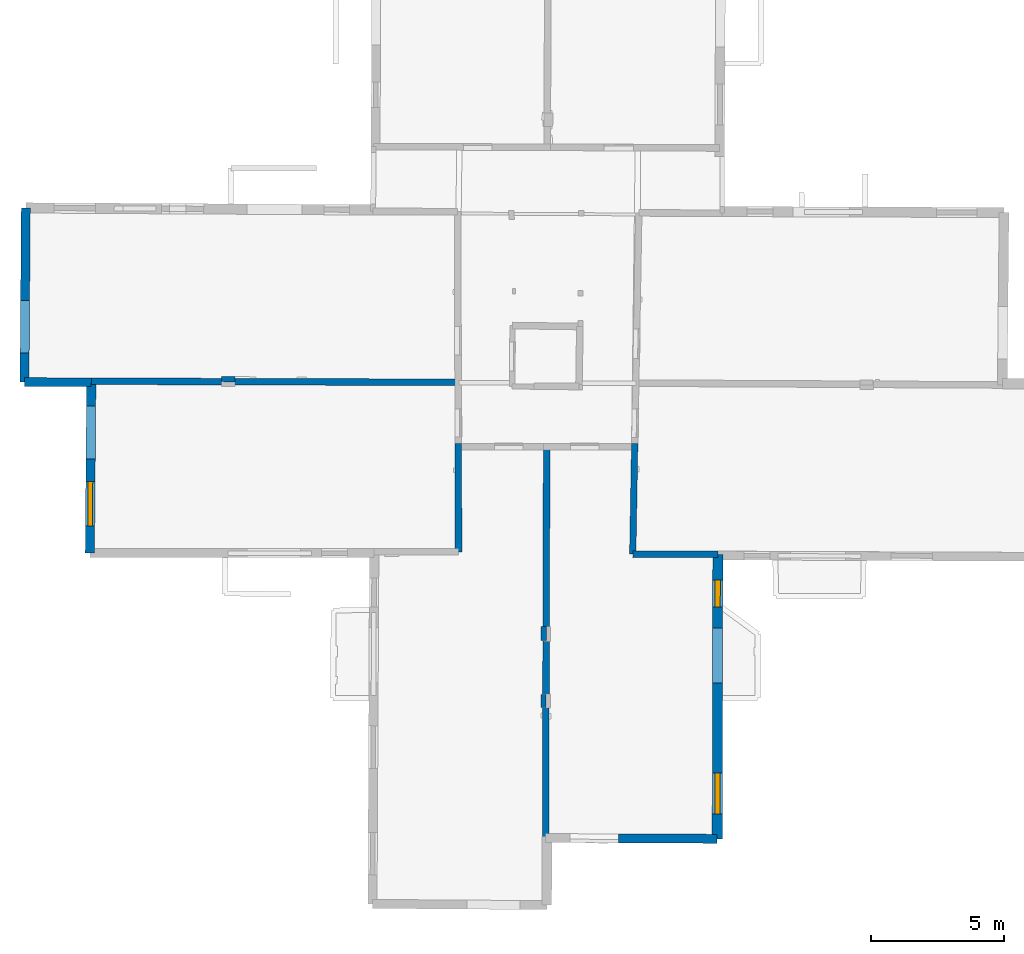
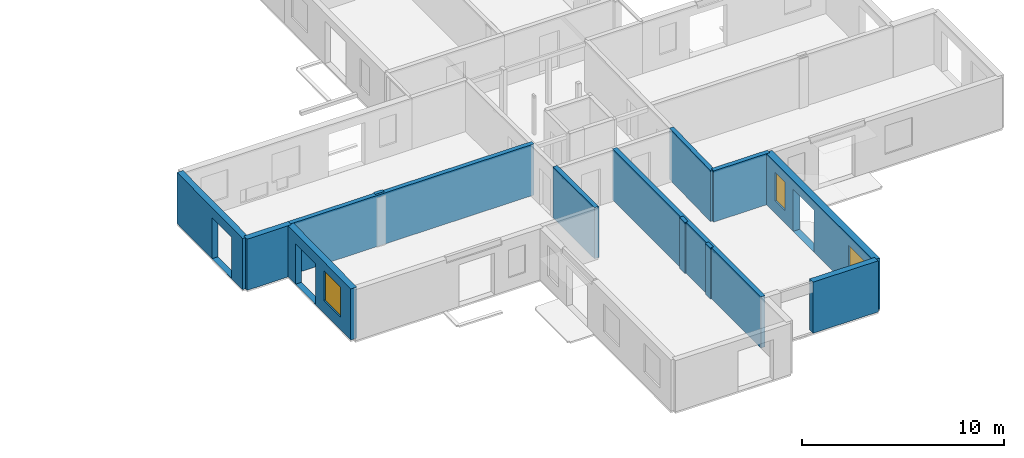
# One storey, part 4 of 17: 13 walls, 3 windows, 6 openings.
"""IFC2X3 building model written with IfcOpenShell, lengths in metres."""

from ifc_helpers import new_model, entity, si_unit, converted_unit, derived_unit, direction, frame, frame_2d, origin, origin_2d_with_axis, place, context, subcontext, project, spatial, polyline, rectangle, outline, extrude, clip, halfspace, source, transform, mapped, material, layer, layer_set, layer_usage, type_object, type_shapes, element, fill, save


model = new_model("IFC2X3")

# Units and contexts
model_context = context("Model", 3, precision=1e-05, world=origin(), true_north=direction((0.0, 1.0)))
body_context = subcontext(model_context, "Body", "Model", "MODEL_VIEW")
ifc_project = project(units=[si_unit("LENGTHUNIT", "METRE"), si_unit("AREAUNIT", "SQUARE_METRE"), si_unit("VOLUMEUNIT", "CUBIC_METRE"), converted_unit("PLANEANGLEUNIT", "DEGREE", entity("IfcRatioMeasure", 0.0174532925199433), si_unit("PLANEANGLEUNIT", "RADIAN"), dimensions=[0, 0, 0, 0, 0, 0, 0]), si_unit("MASSUNIT", "GRAM", prefix="KILO"), derived_unit("MASSDENSITYUNIT", [(si_unit("MASSUNIT", "GRAM", prefix="KILO"), 1), (si_unit("LENGTHUNIT", "METRE"), -3)]), derived_unit("MOMENTOFINERTIAUNIT", [(si_unit("LENGTHUNIT", "METRE"), 4)]), si_unit("TIMEUNIT", "SECOND"), si_unit("FREQUENCYUNIT", "HERTZ"), si_unit("THERMODYNAMICTEMPERATUREUNIT", "DEGREE_CELSIUS"), derived_unit("THERMALTRANSMITTANCEUNIT", [(si_unit("MASSUNIT", "GRAM", prefix="KILO"), 1), (si_unit("THERMODYNAMICTEMPERATUREUNIT", "KELVIN"), -1), (si_unit("TIMEUNIT", "SECOND"), -3)]), derived_unit("VOLUMETRICFLOWRATEUNIT", [(si_unit("LENGTHUNIT", "METRE"), 3), (si_unit("TIMEUNIT", "SECOND"), -1)]), si_unit("ELECTRICCURRENTUNIT", "AMPERE"), si_unit("ELECTRICVOLTAGEUNIT", "VOLT"), si_unit("POWERUNIT", "WATT"), si_unit("FORCEUNIT", "NEWTON", prefix="KILO"), si_unit("ILLUMINANCEUNIT", "LUX"), si_unit("LUMINOUSFLUXUNIT", "LUMEN"), si_unit("LUMINOUSINTENSITYUNIT", "CANDELA"), derived_unit("USERDEFINED", [(si_unit("MASSUNIT", "GRAM", prefix="KILO"), -1), (si_unit("LENGTHUNIT", "METRE"), -2), (si_unit("TIMEUNIT", "SECOND"), 3), (si_unit("LUMINOUSFLUXUNIT", "LUMEN"), 1)]), derived_unit("LINEARVELOCITYUNIT", [(si_unit("LENGTHUNIT", "METRE"), 1), (si_unit("TIMEUNIT", "SECOND"), -1)]), si_unit("PRESSUREUNIT", "PASCAL"), derived_unit("USERDEFINED", [(si_unit("LENGTHUNIT", "METRE"), -2), (si_unit("MASSUNIT", "GRAM", prefix="KILO"), 1), (si_unit("TIMEUNIT", "SECOND"), -2)]), derived_unit("LINEARFORCEUNIT", [(si_unit("MASSUNIT", "GRAM", prefix="KILO"), 1), (si_unit("LENGTHUNIT", "METRE"), 1), (si_unit("TIMEUNIT", "SECOND"), -2), (si_unit("LENGTHUNIT", "METRE"), -1)]), derived_unit("PLANARFORCEUNIT", [(si_unit("MASSUNIT", "GRAM", prefix="KILO"), 1), (si_unit("LENGTHUNIT", "METRE"), 1), (si_unit("TIMEUNIT", "SECOND"), -2), (si_unit("LENGTHUNIT", "METRE"), -2)])], contexts=[model_context])

# Site, building, storey
placement = place(None, origin())
site = spatial("IfcSite", under=ifc_project, at=placement, CompositionType="ELEMENT")
building = spatial("IfcBuilding", under=site, at=placement, CompositionType="ELEMENT")
storey_placement = place(placement, frame((0.0, 0.0, 12.0782108306885)))
storey = spatial("IfcBuildingStorey", under=building, at=storey_placement, Name="Level 5", CompositionType="ELEMENT", Elevation=12.0782108306885)

# Walls
ifc_material_1 = material(Name="Default wall")
ifc_layer_1 = layer(ifc_material_1, 0.25)
ifc_layer_set_1 = layer_set([ifc_layer_1], Name="wall_thickness_0.2500")
ifc_layer_usage_1 = layer_usage(ifc_layer_set_1, "AXIS2", "POSITIVE", -0.125)
wall_type_1 = type_object("IfcWallType", Name="wall_thickness_0.2500", PredefinedType="STANDARD", material=ifc_layer_set_1)
wall_1_placement = place(storey_placement, frame((9.43781448471923, 12.9598951687041, 0.0), z_axis=(0.0, 0.0, 1.0), x_axis=(0.999992090517614, -0.00397729835595546, 0.0)))
element("IfcWallStandardCase", 1, at=wall_1_placement, inside=storey, type_object=wall_type_1, material=ifc_layer_usage_1, Name="Wall:256", ObjectType="Wall", context=body_context, shape_type="Clipping", body=[
    clip(clip(extrude(outline(polyline([(3.20824871848224, -0.125), (3.20824871848224, 0.125), (0.0, 0.125), (0.0, -0.125), (3.20824871848224, -0.125)])), origin(), (0.0, 0.0, 1.0), 3.09134044647217), halfspace(frame((-21.4971284147456, 6.54858542448674, 8.98689858314154), z_axis=(-0.00274595681846049, -0.389131818215703, 0.921177989192801), x_axis=(0.999982875526521, -0.0058292237624909, 0.000518463148508191)), False)), halfspace(frame((3.12303559283847, 64.2896526154921, 6.35864093399329), z_axis=(0.390499965286764, -0.000350666726695465, 0.920602875372374), x_axis=(-0.681032629723905, -0.672971905623566, 0.288623234499112)), False)),
])
wall_2_placement = place(storey_placement, frame((2.85603882370737, 17.1352351598034, 0.0), z_axis=(0.0, 0.0, 1.0), x_axis=(0.00271867720690838, -0.999996304390294, 0.0)))
element("IfcWallStandardCase", 2, at=wall_2_placement, inside=storey, type_object=wall_type_1, material=ifc_layer_usage_1, Name="Wall:278", ObjectType="Wall", context=body_context, shape_type="Clipping", body=[
    clip(clip(extrude(outline(polyline([(4.09139428584585, -0.125), (4.09139428584585, 0.125), (0.0, 0.125), (0.0, -0.125), (4.09139428584585, -0.125)])), origin(), (0.0, 0.0, 1.0), 3.09134044647217), halfspace(frame((-2.49916380210772, -14.8823976244006, 8.98689858314154), z_axis=(0.389104707877538, -0.00535149831765918, 0.921177989192801), x_axis=(0.0125249177791981, 0.999921425728336, 0.000518463148508191)), False)), halfspace(frame((-58.7195490774422, -3.95921476846437, 5.79573318480268), z_axis=(-0.00247443177286369, -0.389892921938171, 0.920856876289642), x_axis=(0.00805044237294521, 0.920820823416222, 0.389902810378011)), False)),
])
wall_3_placement = place(storey_placement, frame((6.19052646799944, 17.0089868537105, 0.0), z_axis=(0.0, 0.0, 1.0), x_axis=(-0.00281216975560108, -0.999996045842815, 0.0)))
element("IfcWallStandardCase", 3, at=wall_3_placement, inside=storey, type_object=wall_type_1, material=ifc_layer_usage_1, Name="Wall:351", ObjectType="Wall", context=body_context, shape_type="Clipping", body=[
    clip(extrude(outline(polyline([(14.7613904039226, -0.125), (14.7613904039226, 0.125), (0.0, 0.125), (0.0, -0.125), (14.7613904039226, -0.125)])), origin(), (0.0, 0.0, 1.0), 3.09134044647217), halfspace(frame((-60.2460264700431, 6.45660151449887, 6.35864093399329), z_axis=(0.000805651711142417, 0.390499291652927, 0.920602875372374), x_axis=(0.672177953798088, -0.681816270658809, 0.288623234499112)), False)),
])
wall_4_placement = place(storey_placement, frame((-10.9863826163068, 19.4781709457927, 0.0), z_axis=(0.0, 0.0, 1.0), x_axis=(0.99999559192, -0.00296919864096198, 0.0)))
element("IfcWallStandardCase", 4, at=wall_4_placement, inside=storey, type_object=wall_type_1, material=ifc_layer_usage_1, Name="Wall:367", ObjectType="Wall", context=body_context, shape_type="Clipping", body=[
    clip(extrude(outline(polyline([(13.8907873211793, -0.125), (13.8907873211793, 0.125), (0.0, 0.125), (0.0, -0.125), (13.8907873211793, -0.125)])), origin(), (0.0, 0.0, 1.0), 3.09134044647217), halfspace(frame((-1.04705470003284, 0.112649928156324, 8.98689858314154), z_axis=(-0.00313824141450819, -0.389128852268156, 0.921177989192801), x_axis=(0.999976490923063, -0.00683730920472676, 0.000518463148508191)), False)),
])
ifc_layer_2 = layer(ifc_material_1, 0.330000013113022)
ifc_layer_set_2 = layer_set([ifc_layer_2], Name="wall_thickness_0.3300")
ifc_layer_usage_2 = layer_usage(ifc_layer_set_2, "AXIS2", "POSITIVE", -0.165000006556511)
wall_type_2 = type_object("IfcWallType", Name="wall_thickness_0.3300", PredefinedType="STANDARD", material=ifc_layer_set_2)
wall_5_placement = place(storey_placement, frame((-13.5041588449196, 19.4468160164166, 0.0), z_axis=(0.0, 0.0, 1.0), x_axis=(0.999997135838471, -0.00239338982485453, 0.0)))
element("IfcWallStandardCase", 5, at=wall_5_placement, inside=storey, type_object=wall_type_2, material=ifc_layer_usage_2, Name="Wall:247", ObjectType="Wall", context=body_context, shape_type="SweptSolid", body=[
    extrude(outline(polyline([(2.51748138497284, -0.165000006556511), (2.51748138497284, 0.165000006556511), (0.0, 0.165000006556511), (0.0, -0.165000006556511), (2.51748138497284, -0.165000006556511)])), origin(), (0.0, 0.0, 1.0), 3.09134044647217),
])

# Wall, openings, window
ifc_layer_3 = layer(ifc_material_1, 0.349999994039536)
ifc_layer_set_3 = layer_set([ifc_layer_3], Name="wall_thickness_0.3500")
ifc_layer_usage_3 = layer_usage(ifc_layer_set_3, "AXIS2", "POSITIVE", -0.174999997019768)
wall_type_3 = type_object("IfcWallType", Name="wall_thickness_0.3500", PredefinedType="STANDARD", material=ifc_layer_set_3)
wall_6_placement = place(storey_placement, frame((-10.9863817701977, 19.4781705652483, 0.0), z_axis=(0.0, 0.0, 1.0), x_axis=(-0.00811924451984643, -0.99996703839098, 0.0)))
wall_6 = element("IfcWallStandardCase", 6, at=wall_6_placement, inside=storey, type_object=wall_type_3, material=ifc_layer_usage_3, Name="Wall:234", ObjectType="Wall", context=body_context, shape_type="Clipping", body=[
    clip(extrude(outline(polyline([(6.47783650575404, -0.174999997019768), (6.47783650575404, 0.174999997019768), (0.0, 0.174999997019768), (0.0, -0.174999997019768), (6.47783650575404, -0.174999997019768)])), origin(), (0.0, 0.0, 1.0), 3.09134044647217), halfspace(frame((-0.107256363123766, -1.04762182256688, 8.98689858314154), z_axis=(0.389139853964676, -0.00113414419666369, 0.921177989192801), x_axis=(0.00168723164517169, 0.999998442221456, 0.000518463148508191)), False)),
])
opening_1_placement = place(wall_6_placement, frame((0.936069885868087, -0.174999997019768, 0.00578975677490234)))
element("IfcOpeningElement", 7, at=opening_1_placement, cuts=wall_6, Name="Opening : 1995 x 2445 : 208", ObjectType="Opening", context=body_context, shape_type="SweptSolid", body=[
    extrude(rectangle(XDim=1.995, YDim=2.445, at=frame_2d((1.2225, 0.9975), x_axis=(0.0, 1.0))), frame((0.0, 0.0, 0.0), z_axis=(0.0, 1.0, 0.0), x_axis=(0.0, 0.0, 1.0)), (0.0, 0.0, 1.0), 0.349999994039536),
])
opening_2_placement = place(wall_6_placement, frame((3.77431154989189, -0.174999997019768, 0.745789527893066)))
opening_2 = element("IfcOpeningElement", 8, at=opening_2_placement, cuts=wall_6, Name="Opening : 1685 x 1830 : 209", ObjectType="Opening", context=body_context, shape_type="SweptSolid", body=[
    extrude(rectangle(XDim=1.685, YDim=1.83, at=frame_2d((0.915, 0.8425), x_axis=(0.0, 1.0))), frame((0.0, 0.0, 0.0), z_axis=(0.0, 1.0, 0.0), x_axis=(0.0, 0.0, 1.0)), (0.0, 0.0, 1.0), 0.349999994039536),
])
ifc_material_2 = material(Name="Window Default")
window_style_1 = type_object("IfcWindowStyle", Name="Window : 1685 x 1830mm", ConstructionType="NOTDEFINED", OperationType="NOTDEFINED", ParameterTakesPrecedence=False, Sizeable=False, material=ifc_material_2)
shared_shape_1 = source(origin(), body_context, "Body", "SweptSolid", [
    extrude(rectangle(XDim=0.174999997019768, YDim=1.685, at=origin_2d_with_axis()), frame((0.8425, 0.174999997019768, 0.0), z_axis=(0.0, 0.0, 1.0), x_axis=(0.0, 1.0, 0.0)), (0.0, 0.0, 1.0), 1.83),
])
type_shapes(window_style_1, [shared_shape_1])
window_1_placement = place(opening_2_placement, origin())
window_1 = element("IfcWindow", 9, at=window_1_placement, inside=storey, type_object=window_style_1, Name="Window : 1685 x 1830mm : 111", ObjectType="Window : 1685 x 1830mm", OverallHeight=1.83, OverallWidth=1.685, context=body_context, shape_type="MappedRepresentation", body=[
    mapped(shared_shape_1, transform((0.0, 0.0, 0.0), scale=1.0)),
])
fill(opening_2, window_1)

# Walls
ifc_layer_4 = layer(ifc_material_1, 0.2)
ifc_layer_set_4 = layer_set([ifc_layer_4], Name="wall_thickness_0.2000")
ifc_layer_usage_4 = layer_usage(ifc_layer_set_4, "AXIS2", "POSITIVE", -0.1)
wall_type_4 = type_object("IfcWallType", Name="wall_thickness_0.2000", PredefinedType="STANDARD", material=ifc_layer_set_4)
wall_7_placement = place(storey_placement, frame((6.07211114635304, 7.6596113359581, 0.0), z_axis=(0.0, 0.0, 1.0), x_axis=(0.00125519004012182, -0.999999212248671, 0.0)))
element("IfcWallStandardCase", 10, at=wall_7_placement, inside=storey, type_object=wall_type_4, material=ifc_layer_usage_4, Name="Wall:246", ObjectType="Wall", context=body_context, shape_type="Clipping", body=[
    clip(extrude(outline(polyline([(0.494999798658673, -0.1), (0.494999798658673, 0.1), (0.0, 0.1), (0.0, -0.1), (0.494999798658673, -0.1)])), origin(), (0.0, 0.0, 1.0), 3.09134044647217), halfspace(frame((-68.1933450660519, -7.24932206220788, 5.79573318480268), z_axis=(-0.00190382486173097, -0.389896125706552, 0.920856876289642), x_axis=(0.006702821994395, 0.920831619046957, 0.389902810378011)), False)),
])
wall_8_placement = place(storey_placement, frame((-6.07608410820719, 19.5611724529353, 0.0), z_axis=(0.0, 0.0, 1.0), x_axis=(0.999775176982851, -0.0212036668741235, 0.0)))
element("IfcWallStandardCase", 11, at=wall_8_placement, inside=storey, type_object=wall_type_4, material=ifc_layer_usage_4, Name="Wall:299", ObjectType="Wall", context=body_context, shape_type="Clipping", body=[
    clip(extrude(outline(polyline([(0.50500016285754, -0.1), (0.50500016285754, 0.1), (0.0, 0.1), (0.0, -0.1), (0.50500016285754, -0.1)])), origin(), (0.0, 0.0, 1.0), 3.09134044647217), halfspace(frame((30.4558824767223, 0.321509788647036, 9.08176747891542), z_axis=(-0.00491309531588459, 0.389105139694995, 0.921180249330909), x_axis=(-0.999934900539776, -0.0113985035002245, -0.000518459702406835)), False)),
])
wall_9_placement = place(storey_placement, frame((6.08586352468844, 10.2286585594187, 0.0), z_axis=(0.0, 0.0, 1.0), x_axis=(-0.00992891728192476, -0.999950707085909, 0.0)))
element("IfcWallStandardCase", 12, at=wall_9_placement, inside=storey, type_object=wall_type_4, material=ifc_layer_usage_4, Name="Wall:341", ObjectType="Wall", context=body_context, shape_type="Clipping", body=[
    clip(extrude(outline(polyline([(0.534999516216442, -0.1), (0.534999516216442, 0.1), (0.0, 0.1), (0.0, -0.1), (0.534999516216442, -0.1)])), origin(), (0.0, 0.0, 1.0), 3.09134044647217), halfspace(frame((-65.5389462043063, -7.99978944595068, 5.79573318480268), z_axis=(0.00245690715089695, -0.389893032763264, 0.920856876289642), x_axis=(-0.00359621269922449, 0.920848991807859, 0.389902810378011)), False)),
])
ifc_layer_5 = layer(ifc_material_1, 0.239999994635582)
ifc_layer_set_5 = layer_set([ifc_layer_5], Name="wall_thickness_0.2400")
ifc_layer_usage_5 = layer_usage(ifc_layer_set_5, "AXIS2", "POSITIVE", -0.119999997317791)
wall_type_5 = type_object("IfcWallType", Name="wall_thickness_0.2400", PredefinedType="STANDARD", material=ifc_layer_set_5)
wall_10_placement = place(storey_placement, frame((9.51158185965826, 17.1327075288628, 0.0), z_axis=(0.0, 0.0, 1.0), x_axis=(-0.0176754020416569, -0.999843777878657, 0.0)))
element("IfcWallStandardCase", 13, at=wall_10_placement, inside=storey, type_object=wall_type_5, material=ifc_layer_usage_5, Name="Wall:371", ObjectType="Wall", context=body_context, shape_type="Clipping", body=[
    clip(clip(extrude(outline(polyline([(4.17346444932265, -0.119999997317791), (4.17346444932265, 0.119999997317791), (0.0, 0.119999997317791), (0.0, -0.119999997317791), (4.17346444932265, -0.119999997317791)])), origin(), (0.0, 0.0, 1.0), 3.09134044647217), halfspace(frame((-2.0800263823425, -21.584817409013, 8.98689858314154), z_axis=(0.38913292169268, 0.0025848562100805, 0.921177989192801), x_axis=(-0.00786967383704212, 0.999968899231202, 0.000518463148508191)), False)), halfspace(frame((-60.1529371427199, 2.24206555821058, 6.35864093399329), z_axis=(-0.00499866323097929, 0.390468128305013, 0.920602875372374), x_axis=(0.682237944174665, -0.671749965415405, 0.288623234499112)), False)),
])

# Wall, openings, windows
ifc_layer_6 = layer(ifc_material_1, 0.379999995231628)
ifc_layer_set_6 = layer_set([ifc_layer_6], Name="wall_thickness_0.3800")
ifc_layer_usage_6 = layer_usage(ifc_layer_set_6, "AXIS2", "POSITIVE", -0.189999997615814)
wall_type_6 = type_object("IfcWallType", Name="wall_thickness_0.3800", PredefinedType="STANDARD", material=ifc_layer_set_6)
wall_11_placement = place(storey_placement, frame((12.6460399730317, 12.9471365233397, 0.0), z_axis=(0.0, 0.0, 1.0), x_axis=(-0.00212138123257554, -0.999997749868301, 0.0)))
wall_11 = element("IfcWallStandardCase", 14, at=wall_11_placement, inside=storey, type_object=wall_type_6, material=ifc_layer_usage_6, Name="Wall:262", ObjectType="Wall", context=body_context, shape_type="Clipping", body=[
    clip(extrude(outline(polyline([(10.7272451498298, -0.189999997615814), (10.7272451498298, 0.189999997615814), (0.0, 0.189999997615814), (0.0, -0.189999997615814), (10.7272451498298, -0.189999997615814)])), origin(), (0.0, 0.0, 1.0), 3.09134044647217), halfspace(frame((-64.2896985215401, 0.03410164942516, 6.35864093399329), z_axis=(0.00107540475247325, 0.390498641944803, 0.920602875372374), x_axis=(0.671706801159741, -0.682280442181233, 0.288623234499112)), False)),
])
opening_3_placement = place(wall_11_placement, frame((2.77397778658697, -0.189999997615814, 0.00578975677490234)))
element("IfcOpeningElement", 15, at=opening_3_placement, cuts=wall_11, Name="Opening : 2080 x 2535 : 230", ObjectType="Opening", context=body_context, shape_type="SweptSolid", body=[
    extrude(rectangle(XDim=2.08, YDim=2.535, at=frame_2d((1.2675, 1.04), x_axis=(0.0, 1.0))), frame((0.0, 0.0, 0.0), z_axis=(0.0, 1.0, 0.0), x_axis=(0.0, 0.0, 1.0)), (0.0, 0.0, 1.0), 0.379999995231628),
])
opening_4_placement = place(wall_11_placement, frame((8.2522186824614, -0.189999997615814, 0.79578971862793)))
opening_4 = element("IfcOpeningElement", 16, at=opening_4_placement, cuts=wall_11, Name="Opening : 1540 x 1710 : 231", ObjectType="Opening", context=body_context, shape_type="SweptSolid", body=[
    extrude(rectangle(XDim=1.54, YDim=1.71, at=frame_2d((0.855, 0.77), x_axis=(0.0, 1.0))), frame((0.0, 0.0, 0.0), z_axis=(0.0, 1.0, 0.0), x_axis=(0.0, 0.0, 1.0)), (0.0, 0.0, 1.0), 0.379999995231628),
])
opening_5_placement = place(wall_11_placement, frame((0.972217827011636, -0.189999997615814, 0.745789527893066)))
opening_5 = element("IfcOpeningElement", 17, at=opening_5_placement, cuts=wall_11, Name="Opening : 1010 x 1735 : 232", ObjectType="Opening", context=body_context, shape_type="SweptSolid", body=[
    extrude(rectangle(XDim=1.01, YDim=1.735, at=frame_2d((0.8675, 0.505), x_axis=(0.0, 1.0))), frame((0.0, 0.0, 0.0), z_axis=(0.0, 1.0, 0.0), x_axis=(0.0, 0.0, 1.0)), (0.0, 0.0, 1.0), 0.379999995231628),
])
window_style_2 = type_object("IfcWindowStyle", Name="Window : 1540 x 1710mm", ConstructionType="NOTDEFINED", OperationType="NOTDEFINED", ParameterTakesPrecedence=False, Sizeable=False, material=ifc_material_2)
shared_shape_2 = source(origin(), body_context, "Body", "SweptSolid", [
    extrude(rectangle(XDim=0.189999997615814, YDim=1.54, at=origin_2d_with_axis()), frame((0.77, 0.189999997615814, 0.0), z_axis=(0.0, 0.0, 1.0), x_axis=(0.0, 1.0, 0.0)), (0.0, 0.0, 1.0), 1.71),
])
type_shapes(window_style_2, [shared_shape_2])
window_2_placement = place(opening_4_placement, origin())
window_2 = element("IfcWindow", 18, at=window_2_placement, inside=storey, type_object=window_style_2, Name="Window : 1540 x 1710mm : 125", ObjectType="Window : 1540 x 1710mm", OverallHeight=1.71, OverallWidth=1.54, context=body_context, shape_type="MappedRepresentation", body=[
    mapped(shared_shape_2, transform((0.0, 0.0, 0.0), scale=1.0)),
])
fill(opening_4, window_2)
window_style_3 = type_object("IfcWindowStyle", Name="Window : 1010 x 1735mm", ConstructionType="NOTDEFINED", OperationType="NOTDEFINED", ParameterTakesPrecedence=False, Sizeable=False, material=ifc_material_2)
shared_shape_3 = source(origin(), body_context, "Body", "SweptSolid", [
    extrude(rectangle(XDim=0.189999997615814, YDim=1.01, at=origin_2d_with_axis()), frame((0.505, 0.189999997615814, 0.0), z_axis=(0.0, 0.0, 1.0), x_axis=(0.0, 1.0, 0.0)), (0.0, 0.0, 1.0), 1.735),
])
type_shapes(window_style_3, [shared_shape_3])
window_3_placement = place(opening_5_placement, origin())
window_3 = element("IfcWindow", 19, at=window_3_placement, inside=storey, type_object=window_style_3, Name="Window : 1010 x 1735mm : 126", ObjectType="Window : 1010 x 1735mm", OverallHeight=1.735, OverallWidth=1.01, context=body_context, shape_type="MappedRepresentation", body=[
    mapped(shared_shape_3, transform((0.0, 0.0, 0.0), scale=1.0)),
])
fill(opening_5, window_3)

# Wall
ifc_layer_7 = layer(ifc_material_1, 0.340000003576279)
ifc_layer_set_7 = layer_set([ifc_layer_7], Name="wall_thickness_0.3400")
ifc_layer_usage_7 = layer_usage(ifc_layer_set_7, "AXIS2", "POSITIVE", -0.170000001788139)
wall_type_7 = type_object("IfcWallType", Name="wall_thickness_0.3400", PredefinedType="STANDARD", material=ifc_layer_set_7)
wall_12_placement = place(storey_placement, frame((8.90058396623371, 2.23586538866859, 0.0), z_axis=(0.0, 0.0, 1.0), x_axis=(0.999990821856933, -0.00428441383345808, 0.0)))
element("IfcWallStandardCase", 20, at=wall_12_placement, inside=storey, type_object=wall_type_7, material=ifc_layer_usage_7, Name="Wall:332", ObjectType="Wall", context=body_context, shape_type="Clipping", body=[
    clip(extrude(outline(polyline([(3.7227323794403, -0.170000001788139), (3.7227323794403, 0.170000001788139), (0.0, 0.170000001788139), (0.0, -0.170000001788139), (3.7227323794403, -0.170000001788139)])), origin(), (0.0, 0.0, 1.0), 3.09134044647217), halfspace(frame((3.59457033613134, 75.0168417955035, 6.35864093399329), z_axis=(0.390500054566584, -0.000230737105025832, 0.920602875372374), x_axis=(-0.680825915756767, -0.67318103132904, 0.288623234499112)), False)),
])

# Wall, opening
wall_13_placement = place(storey_placement, frame((-13.4560535972553, 26.0169417962726, 0.0), z_axis=(0.0, 0.0, 1.0), x_axis=(-0.00732205141702574, -0.999973193422227, 0.0)))
wall_13 = element("IfcWallStandardCase", 21, at=wall_13_placement, inside=storey, type_object=wall_type_7, material=ifc_layer_usage_7, Name="Wall:343", ObjectType="Wall", context=body_context, shape_type="SweptSolid", body=[
    extrude(outline(polyline([(6.57030361453745, -0.170000001788139), (6.57030361453745, 0.170000001788139), (0.0, 0.170000001788139), (0.0, -0.170000001788139), (6.57030361453745, -0.170000001788139)])), origin(), (0.0, 0.0, 1.0), 3.09134044647217),
])
opening_6_placement = place(wall_13_placement, frame((3.50172461915861, -0.170000001788139, 0.00578975677490234)))
element("IfcOpeningElement", 22, at=opening_6_placement, cuts=wall_13, Name="Opening : 1980 x 2475 : 292", ObjectType="Opening", context=body_context, shape_type="SweptSolid", body=[
    extrude(rectangle(XDim=1.98, YDim=2.475, at=frame_2d((1.2375, 0.99), x_axis=(0.0, 1.0))), frame((0.0, 0.0, 0.0), z_axis=(0.0, 1.0, 0.0), x_axis=(0.0, 0.0, 1.0)), (0.0, 0.0, 1.0), 0.340000003576279),
])

save(model, "model.ifc")
